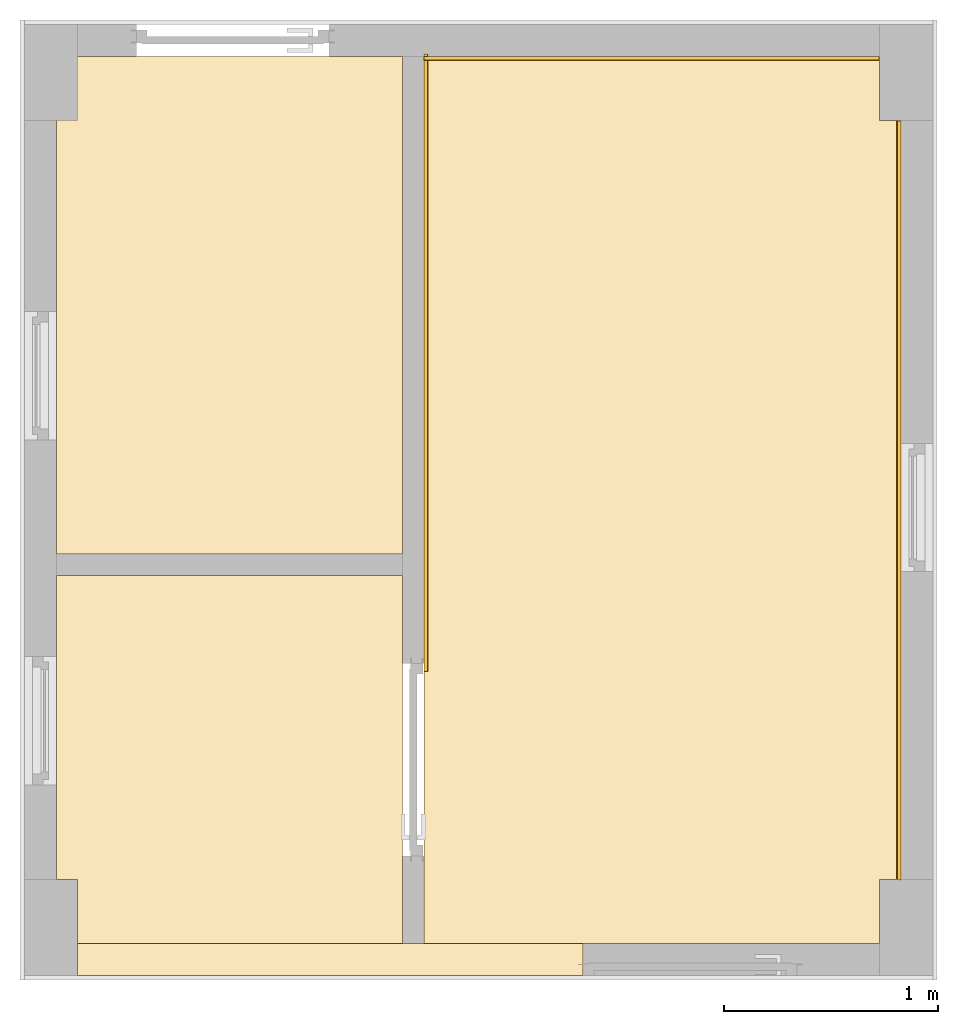
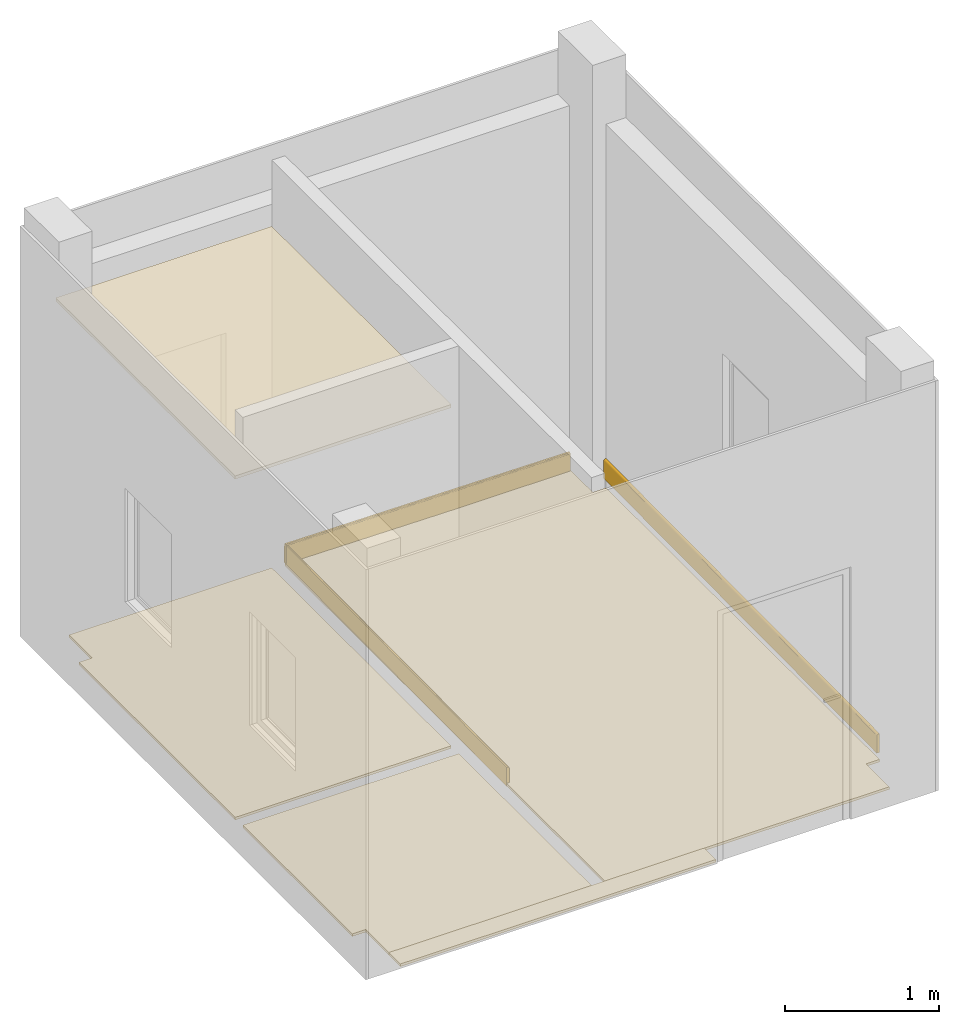
# One storey, part 3 of 3: 8 coverings.
"""IFC4X3_ADD2 building model written with IfcOpenShell, lengths in metres."""

from ifc_helpers import new_model, entity, si_unit, converted_unit, frame, origin_with_axes, origin_2d_with_axis, place, context, subcontext, project, spatial, line, indexed_curve, outline, extrude, material, layer, layer_set, layer_usage, material_profile, profile_set, profile_usage, type_object, element, save


model = new_model("IFC4X3_ADD2")

# Units and contexts
model_context = context("Model", 3, precision=1e-05, world=origin_with_axes())
plan_context = context("Plan", 2, precision=1e-05, world=origin_2d_with_axis())
body_context = subcontext(model_context, "Body", "Model", "MODEL_VIEW")
ifc_project = project(units=[si_unit("VOLUMEUNIT", "CUBIC_METRE"), si_unit("LENGTHUNIT", "METRE"), converted_unit("PLANEANGLEUNIT", "degree", entity("IfcReal", 0.0174532925199433), si_unit("PLANEANGLEUNIT", "RADIAN"), dimensions=[0, 0, 0, 0, 0, 0, 0]), si_unit("AREAUNIT", "SQUARE_METRE")], contexts=[model_context, plan_context])

# Site, building, storey
site_placement = place(None, origin_with_axes())
site = spatial("IfcSite", under=ifc_project, at=site_placement)
building_placement = place(site_placement, origin_with_axes())
building = spatial("IfcBuilding", under=site, at=building_placement, Name="Building")
storey_placement = place(building_placement, origin_with_axes())
storey = spatial("IfcBuildingStorey", under=building, at=storey_placement, Name="G1")

# Coverings
ifc_material = material()
ifc_layer_1 = layer(ifc_material, 0.0199999995529652)
ifc_layer_set_1 = layer_set([ifc_layer_1])
ifc_layer_usage_1 = layer_usage(ifc_layer_set_1, "AXIS3", "POSITIVE", 0.0)
covering_type_1 = type_object("IfcCoveringType", Name="FLR-20", PredefinedType="FLOORING", material=ifc_layer_set_1)
covering_1_placement = place(storey_placement, frame((3.55524206161499, 2.72850346565247, 0.0), z_axis=(0.0, 0.0, 1.0), x_axis=(1.0, 0.0, 0.0)))
element("IfcCovering", 1, at=covering_1_placement, inside=storey, type_object=covering_type_1, material=ifc_layer_usage_1, Name="Covering", context=body_context, shape_type="SweptSolid", body=[
    extrude(outline(indexed_curve([(-2.93024206161499, -2.45350337028503), (-2.93024206161499, -2.30350351333618), (-0.566241979598999, -2.30350351333618), (-0.566241979598999, -2.45350337028503), (-2.93024206161499, -2.45350337028503)], segments=[line(1, 2, 3, 4, 5, 1)])), None, (0.0, 0.0, 1.0), 0.0199999995529652),
])
ifc_layer_usage_2 = layer_usage(ifc_layer_set_1, "AXIS3", "POSITIVE", 0.0)
covering_2_placement = place(storey_placement, frame((3.14984846115112, 0.424999713897705, 0.0), z_axis=(0.0, 0.0, 1.0), x_axis=(1.0, 0.0, 0.0)))
element("IfcCovering", 2, at=covering_2_placement, inside=storey, type_object=covering_type_1, material=ifc_layer_usage_2, Name="FLR-20", context=body_context, shape_type="SweptSolid", body=[
    extrude(outline(indexed_curve([(1.22515165805817, 0.0), (1.22515153884888, 0.300000190734863), (1.32515144348145, 0.300000250339508), (1.32515144348145, 3.85000038146973), (1.22515153884888, 3.85000038146973), (1.22515153884888, 4.15000057220459), (-0.906397581100464, 4.15000057220459), (-0.906397581100464, 0.0), (1.22515165805817, 0.0)])), None, (0.0, 0.0, 1.0), 0.0199999995529652),
])
ifc_layer_usage_3 = layer_usage(ifc_layer_set_1, "AXIS3", "POSITIVE", 0.0)
covering_3_placement = place(storey_placement, frame((0.524999499320984, 2.24741911888123, 0.0), z_axis=(0.0, 0.0, 1.0), x_axis=(1.0, 0.0, 0.0)))
element("IfcCovering", 3, at=covering_3_placement, inside=storey, type_object=covering_type_1, material=ifc_layer_usage_3, Name="FLR-20", context=body_context, shape_type="SweptSolid", body=[
    extrude(outline(indexed_curve([(0.0, 2.02758097648621), (0.0, 0.0), (1.61845135688782, 0.0), (1.61845135688782, 2.32758116722107), (0.100000500679016, 2.32758116722107), (0.100000500679016, 2.02758097648621), (0.0, 2.02758097648621)])), None, (0.0, 0.0, 1.0), 0.0199999995529652),
])
ifc_layer_usage_4 = layer_usage(ifc_layer_set_1, "AXIS3", "POSITIVE", 0.0)
covering_4_placement = place(storey_placement, frame((0.524999618530273, 0.424999952316284, 0.0), z_axis=(0.0, 0.0, 1.0), x_axis=(1.0, 0.0, 0.0)))
element("IfcCovering", 4, at=covering_4_placement, inside=storey, type_object=covering_type_1, material=ifc_layer_usage_4, Name="FLR-20", context=body_context, shape_type="SweptSolid", body=[
    extrude(outline(indexed_curve([(0.0, 0.299999922513962), (0.0, 1.72241902351379), (1.61845088005066, 1.72241902351379), (1.61845088005066, 0.0), (0.100000381469727, 0.0), (0.100000381469727, 0.299999952316284), (0.0, 0.299999922513962)])), None, (0.0, 0.0, 1.0), 0.0199999995529652),
])
ifc_material_profile = material_profile(ifc_material, outline(indexed_curve([(0.0, 0.0), (0.0199999809265137, 0.0), (0.0199999809265137, 0.135982796549797), (0.0197870284318924, 0.13841687142849), (0.019154641777277, 0.140776962041855), (0.0181220360100269, 0.14299139380455), (0.0167205855250359, 0.144992887973785), (0.0149928722530603, 0.146720588207245), (0.0129913929849863, 0.148122042417526), (0.010776961222291, 0.149154648184776), (0.00841686222702265, 0.149787038564682), (0.00598280504345894, 0.149999976158142), (0.0, 0.149999976158142), (0.0, 0.0)])))
ifc_profile_set = profile_set([ifc_material_profile])
ifc_profile_usage_1 = profile_usage(ifc_profile_set, cardinal=1)
covering_type_2 = type_object("IfcCoveringType", Name="SKT-20x150", PredefinedType="SKIRTINGBOARD", material=ifc_profile_set)
covering_5_placement = place(storey_placement, frame((4.46499919891357, 0.725596904754639, 0.0), z_axis=(1.5130010247242e-07, 0.999968309576978, 0.00796114575540763), x_axis=(-0.999999999999988, 1.50995802528085e-07, 3.88243925897309e-08)))
element("IfcCovering", 5, at=covering_5_placement, inside=storey, type_object=covering_type_2, material=ifc_profile_usage_1, Name="20x150", context=body_context, shape_type="SweptSolid", body=[
    extrude(outline(indexed_curve([(0.0, 0.0), (0.0199999809265137, 0.0), (0.0199999809265137, 0.135982796549797), (0.0197870284318924, 0.13841687142849), (0.019154641777277, 0.140776962041855), (0.0181220360100269, 0.14299139380455), (0.0167205855250359, 0.144992887973785), (0.0149928722530603, 0.146720588207245), (0.0129913929849863, 0.148122042417526), (0.010776961222291, 0.149154648184776), (0.00841686222702265, 0.149787038564682), (0.00598280504345894, 0.149999976158142), (0.0, 0.149999976158142), (0.0, 0.0)])), frame((-0.00999999046325684, 0.074999988079071, 0.0), z_axis=(0.0, 0.0, 1.0), x_axis=(1.0, 0.0, 0.0)), (0.0, 0.0, 1.0), 3.54944981417315),
])
ifc_profile_usage_2 = profile_usage(ifc_profile_set, cardinal=1)
covering_6_placement = place(storey_placement, frame((2.25345087051392, 4.5877046585083, -0.0549976117908955), z_axis=(-2.38722923421403e-07, -0.999968309829042, -0.00796111409244625), x_axis=(0.999999999999971, -2.3841585061745e-07, -3.95203691994072e-08)))
element("IfcCovering", 6, at=covering_6_placement, inside=storey, type_object=covering_type_2, material=ifc_profile_usage_2, Name="20x150", context=body_context, shape_type="SweptSolid", body=[
    extrude(outline(indexed_curve([(0.0, 0.0), (0.0199999809265137, 0.0), (0.0199999809265137, 0.135982796549797), (0.0197870284318924, 0.13841687142849), (0.019154641777277, 0.140776962041855), (0.0181220360100269, 0.14299139380455), (0.0167205855250359, 0.144992887973785), (0.0149928722530603, 0.146720588207245), (0.0129913929849863, 0.148122042417526), (0.010776961222291, 0.149154648184776), (0.00841686222702265, 0.149787038564682), (0.00598280504345894, 0.149999976158142), (0.0, 0.149999976158142), (0.0, 0.0)])), frame((-0.00999999046325684, 0.074999988079071, 0.0), z_axis=(0.0, 0.0, 1.0), x_axis=(1.0, 0.0, 0.0)), (0.0, 0.0, 1.0), 2.8871068965329),
])
ifc_profile_usage_3 = profile_usage(ifc_profile_set, cardinal=1)
covering_7_placement = place(storey_placement, frame((4.3698148727417, 4.5649995803833, -0.0624970011413097), z_axis=(-0.999968311474905, 4.02283100678192e-07, 0.00796090735193364), x_axis=(-4.01339264044474e-07, -0.999999999999912, 1.2015738093395e-07)))
element("IfcCovering", 7, at=covering_7_placement, inside=storey, type_object=covering_type_2, material=ifc_profile_usage_3, Name="20x150", context=body_context, shape_type="SweptSolid", body=[
    extrude(outline(indexed_curve([(0.0, 0.0), (0.0199999809265137, 0.0), (0.0199999809265137, 0.135982796549797), (0.0197870284318924, 0.13841687142849), (0.019154641777277, 0.140776962041855), (0.0181220360100269, 0.14299139380455), (0.0167205855250359, 0.144992887973785), (0.0149928722530603, 0.146720588207245), (0.0129913929849863, 0.148122042417526), (0.010776961222291, 0.149154648184776), (0.00841686222702265, 0.149787038564682), (0.00598280504345894, 0.149999976158142), (0.0, 0.149999976158142), (0.0, 0.0)])), frame((-0.00999999046325684, 0.074999988079071, 0.0), z_axis=(0.0, 0.0, 1.0), x_axis=(1.0, 0.0, 0.0)), (0.0, 0.0, 1.0), 2.12822288143722),
])
ifc_layer_2 = layer(ifc_material, 0.025000000372529)
ifc_layer_set_2 = layer_set([ifc_layer_2])
ifc_layer_usage_5 = layer_usage(ifc_layer_set_2, "AXIS3", "POSITIVE", 0.0)
covering_type_3 = type_object("IfcCoveringType", Name="CEL-20", PredefinedType="CEILING", material=ifc_layer_set_2)
covering_8_placement = place(storey_placement, frame((0.524999737739563, 3.63607096672058, 2.70000004768372), z_axis=(0.0, 0.0, 1.0), x_axis=(1.0, 0.0, 0.0)))
element("IfcCovering", 8, at=covering_8_placement, inside=storey, type_object=covering_type_3, material=ifc_layer_usage_5, Name="20", context=body_context, shape_type="SweptSolid", body=[
    extrude(outline(indexed_curve([(0.0, 0.938929080963135), (1.61844897270203, 0.938929080963135), (1.61844897270203, -1.38865220546722), (0.0, -1.38865220546722), (0.0, 0.938929080963135)])), None, (0.0, 0.0, 1.0), 0.025000000372529),
])

save(model, "model.ifc")
